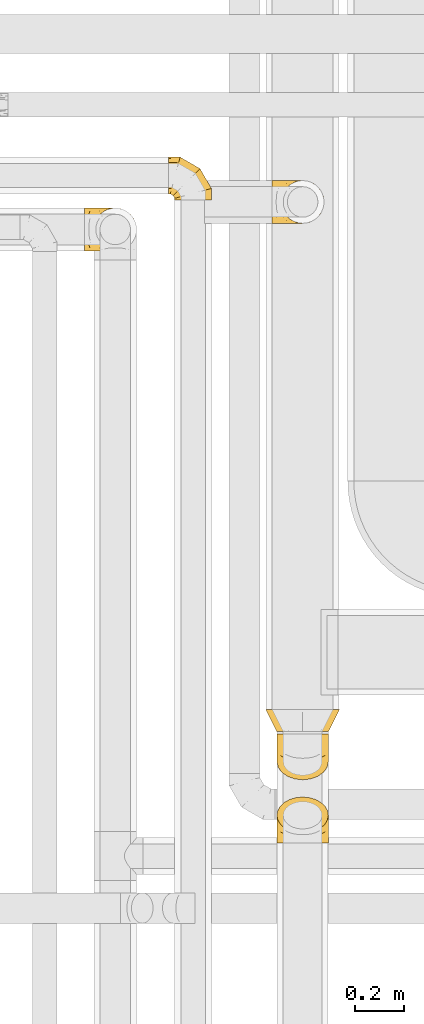
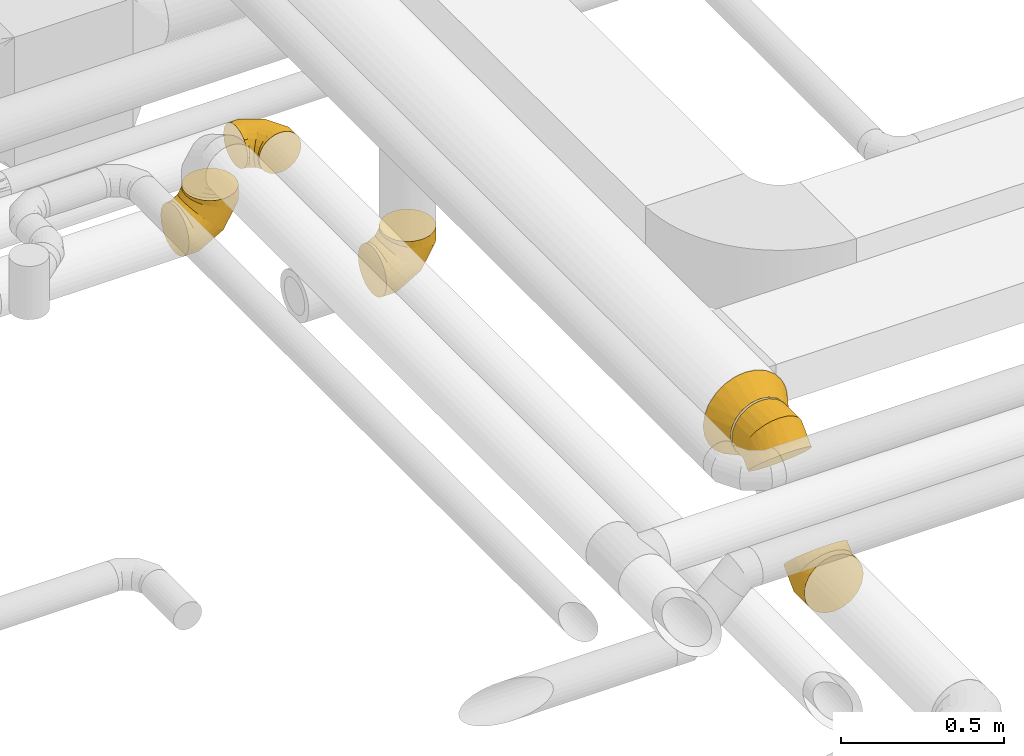
# One storey, part 24 of 92: 6 coverings.
"""IFC2X3 building model written with IfcOpenShell, lengths in millimetres."""

from ifc_helpers import new_model, entity, si_unit, converted_unit, derived_unit, direction, frame, origin, place, context, subcontext, project, spatial, faceted_brep, element, save


model = new_model("IFC2X3")

# Units and contexts
model_context = context("Model", 3, precision=0.01, world=origin(), true_north=direction((6.12303176911189e-17, 1.0)))
body_context = subcontext(model_context, "Body", "Model", "MODEL_VIEW")
ifc_project = project(units=[si_unit("LENGTHUNIT", "METRE", prefix="MILLI"), si_unit("AREAUNIT", "SQUARE_METRE"), si_unit("VOLUMEUNIT", "CUBIC_METRE"), converted_unit("PLANEANGLEUNIT", "DEGREE", entity("IfcRatioMeasure", 0.0174532925199433), si_unit("PLANEANGLEUNIT", "RADIAN"), dimensions=[0, 0, 0, 0, 0, 0, 0]), si_unit("MASSUNIT", "GRAM", prefix="KILO"), derived_unit("MASSDENSITYUNIT", [(si_unit("MASSUNIT", "GRAM", prefix="KILO"), 1), (si_unit("LENGTHUNIT", "METRE"), -3)]), derived_unit("MOMENTOFINERTIAUNIT", [(si_unit("LENGTHUNIT", "METRE"), 4)]), si_unit("TIMEUNIT", "SECOND"), si_unit("FREQUENCYUNIT", "HERTZ"), si_unit("THERMODYNAMICTEMPERATUREUNIT", "DEGREE_CELSIUS"), derived_unit("THERMALTRANSMITTANCEUNIT", [(si_unit("MASSUNIT", "GRAM", prefix="KILO"), 1), (si_unit("THERMODYNAMICTEMPERATUREUNIT", "KELVIN"), -1), (si_unit("TIMEUNIT", "SECOND"), -3)]), derived_unit("VOLUMETRICFLOWRATEUNIT", [(si_unit("LENGTHUNIT", "METRE"), 3), (si_unit("TIMEUNIT", "SECOND"), -1)]), derived_unit("MASSFLOWRATEUNIT", [(si_unit("MASSUNIT", "GRAM", prefix="KILO"), 1), (si_unit("TIMEUNIT", "SECOND"), -1)]), derived_unit("ROTATIONALFREQUENCYUNIT", [(si_unit("TIMEUNIT", "SECOND"), -1)]), si_unit("ELECTRICCURRENTUNIT", "AMPERE"), si_unit("ELECTRICVOLTAGEUNIT", "VOLT"), si_unit("POWERUNIT", "WATT"), si_unit("FORCEUNIT", "NEWTON", prefix="KILO"), si_unit("ILLUMINANCEUNIT", "LUX"), si_unit("LUMINOUSFLUXUNIT", "LUMEN"), si_unit("LUMINOUSINTENSITYUNIT", "CANDELA"), derived_unit("USERDEFINED", [(si_unit("MASSUNIT", "GRAM", prefix="KILO"), -1), (si_unit("LENGTHUNIT", "METRE"), -2), (si_unit("TIMEUNIT", "SECOND"), 3), (si_unit("LUMINOUSFLUXUNIT", "LUMEN"), 1)]), derived_unit("LINEARVELOCITYUNIT", [(si_unit("LENGTHUNIT", "METRE"), 1), (si_unit("TIMEUNIT", "SECOND"), -1)]), si_unit("PRESSUREUNIT", "PASCAL"), derived_unit("USERDEFINED", [(si_unit("LENGTHUNIT", "METRE"), -2), (si_unit("MASSUNIT", "GRAM", prefix="KILO"), 1), (si_unit("TIMEUNIT", "SECOND"), -2)]), derived_unit("LINEARFORCEUNIT", [(si_unit("MASSUNIT", "GRAM", prefix="KILO"), 1), (si_unit("LENGTHUNIT", "METRE"), 1), (si_unit("TIMEUNIT", "SECOND"), -2), (si_unit("LENGTHUNIT", "METRE"), -1)]), derived_unit("PLANARFORCEUNIT", [(si_unit("MASSUNIT", "GRAM", prefix="KILO"), 1), (si_unit("LENGTHUNIT", "METRE"), 1), (si_unit("TIMEUNIT", "SECOND"), -2), (si_unit("LENGTHUNIT", "METRE"), -2)])], contexts=[model_context])

# Site, building, storey
site_placement = place(None, origin())
site = spatial("IfcSite", under=ifc_project, at=site_placement, CompositionType="ELEMENT")
building_placement = place(site_placement, origin())
building = spatial("IfcBuilding", under=site, at=building_placement, CompositionType="ELEMENT")
storey_placement = place(building_placement, frame((0.0, 0.0, 4200.0)))
storey = spatial("IfcBuildingStorey", under=building, at=storey_placement, CompositionType="ELEMENT", Elevation=4200.0)

# Coverings
covering_1_placement = place(storey_placement, frame((60960.0, 11327.66, 2510.9)))
element("IfcCovering", 1, at=covering_1_placement, inside=storey, PredefinedType="INSULATION", context=body_context, shape_type="Brep", body=[
    faceted_brep([(97.96, 5.88, 214.1), (125.0, 1.6, 214.1), (152.04, 5.88, 214.1), (176.43, 18.31, 214.1), (195.79, 37.66, 214.1), (208.22, 62.06, 214.1), (212.5, 89.1, 214.1), (208.22, 116.13, 214.1), (195.79, 140.53, 214.1), (176.43, 159.88, 214.1), (152.04, 172.31, 214.1), (125.0, 176.6, 214.1), (97.96, 172.31, 214.1), (73.57, 159.88, 214.1), (54.21, 140.53, 214.1), (48.0, 128.33, 214.1), (41.78, 116.13, 214.1), (39.64, 102.61, 214.1), (37.5, 89.1, 214.1), (39.64, 75.58, 214.1), (41.78, 62.06, 214.1), (48.0, 49.86, 214.1), (54.21, 37.66, 214.1), (73.57, 18.31, 214.1), (0.0, 132.85, 13.32), (0.0, 111.74, 4.58), (0.0, 89.1, 1.6), (0.0, 66.45, 4.58), (0.0, 45.35, 13.32), (0.0, 27.22, 27.22), (0.0, 13.32, 45.35), (0.0, 4.58, 66.45), (0.0, 1.6, 89.1), (0.0, 4.58, 111.74), (0.0, 13.32, 132.85), (0.0, 27.22, 150.97), (0.0, 45.35, 164.87), (0.0, 66.45, 173.61), (0.0, 89.1, 176.6), (0.0, 111.74, 173.61), (0.0, 132.85, 164.87), (0.0, 150.97, 150.97), (0.0, 164.87, 132.85), (0.0, 173.61, 111.74), (0.0, 176.6, 89.1), (0.0, 173.61, 66.45), (0.0, 164.87, 45.35), (0.0, 150.97, 27.22), (56.94, 89.1, 1.6), (56.14, 66.45, 4.58), (53.8, 45.35, 13.32), (50.07, 27.22, 27.22), (45.22, 13.32, 45.35), (39.56, 4.58, 66.45), (33.49, 1.6, 89.1), (27.43, 4.58, 111.74), (21.77, 13.32, 132.85), (16.92, 27.22, 150.97), (13.19, 45.35, 164.87), (10.85, 66.45, 173.61), (10.05, 89.1, 176.6), (10.85, 111.74, 173.61), (13.19, 132.85, 164.87), (16.92, 150.97, 150.97), (27.43, 173.61, 111.74), (33.49, 176.6, 89.1), (21.77, 164.87, 132.85), (39.56, 173.61, 66.45), (45.22, 164.87, 45.35), (50.07, 150.97, 27.22), (53.8, 132.85, 13.32), (56.14, 111.74, 4.58), (155.56, 89.1, 58.53), (153.38, 66.45, 60.72), (146.98, 45.35, 67.12), (136.8, 27.22, 77.3), (123.53, 13.32, 90.56), (108.08, 4.58, 106.01), (91.51, 1.6, 122.59), (74.93, 4.58, 139.17), (59.48, 13.32, 154.62), (46.21, 27.22, 167.88), (36.03, 45.35, 178.06), (29.63, 66.45, 184.46), (27.45, 89.1, 186.64), (29.63, 111.74, 184.46), (36.03, 132.85, 178.06), (46.21, 150.97, 167.88), (74.93, 173.61, 139.17), (91.51, 176.6, 122.59), (59.48, 164.87, 154.62), (108.08, 173.61, 106.01), (123.53, 164.87, 90.56), (136.8, 150.97, 77.3), (146.98, 132.85, 67.12), (153.38, 111.74, 60.72), (212.5, 89.1, 157.16), (209.52, 66.45, 157.95), (200.78, 45.35, 160.3), (186.87, 27.22, 164.02), (168.75, 13.32, 168.88), (147.65, 4.58, 174.53), (125.0, 1.6, 180.6), (102.35, 4.58, 186.67), (81.25, 13.32, 192.32), (63.13, 27.22, 197.18), (49.22, 45.35, 200.91), (40.48, 66.45, 203.25), (38.99, 77.77, 203.65), (37.5, 89.1, 204.05), (40.48, 111.74, 203.25), (49.22, 132.85, 200.91), (38.99, 100.42, 203.65), (63.13, 150.97, 197.18), (102.35, 173.61, 186.67), (125.0, 176.6, 180.6), (81.25, 164.87, 192.32), (147.65, 173.61, 174.53), (168.75, 164.87, 168.88), (186.87, 150.97, 164.02), (200.78, 132.85, 160.3), (209.52, 111.74, 157.95)], [[[0, 1, 2, 3, 4, 5, 6, 7, 8, 9, 10, 11, 12, 13, 14, 15, 16, 17, 18, 19, 20, 21, 22, 23]], [[24, 25, 26, 27, 28, 29, 30, 31, 32, 33, 34, 35, 36, 37, 38, 39, 40, 41, 42, 43, 44, 45, 46, 47]], [[26, 48, 49, 27]], [[27, 49, 50, 28]], [[28, 50, 51, 29]], [[30, 52, 53, 31]], [[31, 53, 54, 32]], [[29, 51, 52, 30]], [[55, 56, 34, 33]], [[54, 55, 33, 32]], [[57, 35, 34, 56]], [[58, 59, 37, 36]], [[58, 36, 35, 57]], [[60, 38, 37, 59]], [[61, 62, 40, 39]], [[60, 61, 39, 38]], [[41, 40, 62, 63]], [[64, 65, 44, 43]], [[66, 64, 43, 42]], [[63, 66, 42, 41]], [[46, 45, 67, 68]], [[47, 46, 68, 69]], [[44, 65, 67, 45]], [[25, 24, 70, 71]], [[26, 25, 71, 48]], [[69, 70, 24, 47]], [[49, 48, 72, 73]], [[50, 49, 73, 74]], [[74, 75, 51, 50]], [[52, 51, 75, 76]], [[53, 52, 76, 77]], [[54, 53, 77, 78]], [[79, 80, 56, 55]], [[78, 79, 55, 54]], [[57, 56, 80, 81]], [[82, 83, 59, 58]], [[81, 82, 58, 57]], [[60, 59, 83, 84]], [[85, 86, 62, 61]], [[84, 85, 61, 60]], [[63, 62, 86, 87]], [[88, 89, 65, 64]], [[90, 88, 64, 66]], [[87, 90, 66, 63]], [[67, 65, 89, 91]], [[68, 67, 91, 92]], [[69, 68, 92, 93]], [[71, 70, 94, 95]], [[48, 71, 95, 72]], [[93, 94, 70, 69]], [[73, 72, 96, 97]], [[74, 73, 97, 98]], [[98, 99, 75, 74]], [[76, 75, 99, 100]], [[77, 76, 100, 101]], [[78, 77, 101, 102]], [[103, 104, 80, 79]], [[102, 103, 79, 78]], [[81, 80, 104, 105]], [[106, 107, 83, 82]], [[105, 106, 82, 81]], [[84, 83, 107, 108, 109]], [[110, 111, 86, 85]], [[85, 84, 109, 112, 110]], [[87, 86, 111, 113]], [[114, 115, 89, 88]], [[116, 114, 88, 90]], [[113, 116, 90, 87]], [[91, 89, 115, 117]], [[92, 91, 117, 118]], [[93, 92, 118, 119]], [[95, 94, 120, 121]], [[72, 95, 121, 96]], [[119, 120, 94, 93]], [[97, 6, 5]], [[98, 5, 4]], [[6, 97, 96]], [[97, 5, 98]], [[4, 99, 98]], [[100, 3, 2]], [[101, 2, 1]], [[99, 3, 100]], [[100, 2, 101]], [[1, 102, 101]], [[3, 99, 4]], [[103, 1, 0]], [[104, 0, 23]], [[103, 102, 1]], [[104, 103, 0]], [[23, 105, 104]], [[21, 20, 107]], [[18, 109, 108]], [[107, 20, 19]], [[106, 105, 22]], [[106, 22, 21]], [[107, 19, 108]], [[21, 107, 106]], [[18, 108, 19]], [[22, 105, 23]], [[110, 17, 16]], [[111, 15, 14]], [[18, 112, 109]], [[18, 17, 112]], [[110, 16, 15]], [[110, 15, 111]], [[14, 113, 111]], [[116, 13, 12]], [[114, 12, 11]], [[116, 113, 13]], [[115, 114, 11]], [[116, 12, 114]], [[17, 110, 112]], [[13, 113, 14]], [[117, 11, 10]], [[118, 10, 9]], [[11, 117, 115]], [[117, 10, 118]], [[9, 119, 118]], [[120, 8, 7]], [[121, 7, 6]], [[119, 8, 120]], [[121, 120, 7]], [[96, 121, 6]], [[8, 119, 9]]]),
])
covering_2_placement = place(storey_placement, frame((60933.4, 9251.14, 3130.9)))
element("IfcCovering", 2, at=covering_2_placement, inside=storey, PredefinedType="INSULATION", context=body_context, shape_type="Brep", body=[
    faceted_brep([(190.42, 90.0, 296.48), (226.6, 90.0, 281.5), (257.66, 90.0, 257.66), (281.5, 90.0, 226.6), (296.48, 90.0, 190.42), (301.6, 90.0, 151.6), (296.48, 90.0, 112.77), (281.5, 90.0, 76.6), (257.66, 90.0, 45.53), (226.6, 90.0, 21.69), (190.42, 90.0, 6.71), (151.6, 90.0, 1.6), (112.77, 90.0, 6.71), (76.6, 90.0, 21.69), (45.53, 90.0, 45.53), (21.69, 90.0, 76.6), (6.71, 90.0, 112.77), (1.6, 90.0, 151.6), (6.71, 90.0, 190.42), (21.69, 90.0, 226.6), (45.53, 90.0, 257.66), (76.6, 90.0, 281.5), (112.77, 90.0, 296.48), (151.6, 90.0, 301.6), (184.04, 0.0, 251.46), (151.6, 0.0, 256.6), (119.15, 0.0, 251.46), (89.88, 0.0, 236.54), (66.65, 0.0, 213.31), (51.73, 0.0, 184.04), (46.6, 0.0, 151.6), (51.73, 0.0, 119.15), (66.65, 0.0, 89.88), (89.88, 0.0, 66.65), (119.15, 0.0, 51.73), (151.6, 0.0, 46.6), (184.04, 0.0, 51.73), (213.31, 0.0, 66.65), (236.54, 0.0, 89.88), (251.46, 0.0, 119.15), (256.6, 0.0, 151.6), (251.46, 0.0, 184.04), (236.54, 0.0, 213.31), (213.31, 0.0, 236.54)], [[[0, 1, 2, 3, 4, 5, 6, 7, 8, 9, 10, 11, 12, 13, 14, 15, 16, 17, 18, 19, 20, 21, 22, 23]], [[24, 25, 26, 27, 28, 29, 30, 31, 32, 33, 34, 35, 36, 37, 38, 39, 40, 41, 42, 43]], [[6, 40, 39]], [[7, 39, 38]], [[6, 5, 40]], [[7, 6, 39]], [[38, 8, 7]], [[36, 35, 10]], [[37, 36, 9]], [[8, 37, 9]], [[10, 9, 36]], [[11, 10, 35]], [[37, 8, 38]], [[12, 35, 34]], [[13, 34, 33]], [[12, 11, 35]], [[13, 12, 34]], [[33, 14, 13]], [[31, 30, 16]], [[32, 31, 15]], [[14, 32, 15]], [[16, 15, 31]], [[17, 16, 30]], [[32, 14, 33]], [[18, 30, 29]], [[19, 29, 28]], [[18, 17, 30]], [[19, 18, 29]], [[28, 20, 19]], [[26, 25, 22]], [[27, 26, 21]], [[20, 27, 21]], [[22, 21, 26]], [[23, 22, 25]], [[27, 20, 28]], [[0, 25, 24]], [[1, 24, 43]], [[0, 23, 25]], [[1, 0, 24]], [[43, 2, 1]], [[41, 40, 4]], [[42, 41, 3]], [[2, 42, 3]], [[4, 3, 41]], [[5, 4, 40]], [[42, 2, 43]]]),
])
covering_3_placement = place(storey_placement, frame((60978.4, 9052.72, 3159.8)))
element("IfcCovering", 3, at=covering_3_placement, inside=storey, PredefinedType="INSULATION", context=body_context, shape_type="Brep", body=[
    faceted_brep([(6.73, 52.9, 98.78), (1.6, 75.84, 75.84), (6.73, 98.78, 52.9), (21.65, 119.48, 32.2), (44.88, 135.91, 15.78), (74.15, 146.45, 5.23), (106.6, 150.09, 1.6), (139.04, 146.45, 5.23), (168.31, 135.91, 15.78), (191.54, 119.48, 32.2), (206.46, 98.78, 52.9), (211.6, 75.84, 75.84), (206.46, 52.9, 98.78), (191.54, 32.2, 119.48), (168.31, 15.78, 135.91), (139.04, 5.23, 146.45), (106.6, 1.6, 150.09), (74.15, 5.23, 146.45), (44.88, 15.78, 135.91), (21.65, 32.2, 119.48), (54.1, 188.98, 213.64), (79.42, 188.98, 224.13), (106.6, 188.98, 227.7), (133.77, 188.98, 224.13), (159.1, 188.98, 213.64), (180.84, 188.98, 196.95), (197.53, 188.98, 175.2), (208.02, 188.98, 149.88), (211.6, 188.98, 122.7), (208.02, 188.98, 95.53), (197.53, 188.98, 70.2), (180.84, 188.98, 48.46), (159.1, 188.98, 31.77), (133.77, 188.98, 21.28), (106.6, 188.98, 17.7), (79.42, 188.98, 21.28), (54.1, 188.98, 31.77), (32.35, 188.98, 48.46), (15.66, 188.98, 70.2), (5.17, 188.98, 95.53), (1.6, 188.98, 122.7), (5.17, 188.98, 149.88), (15.66, 188.98, 175.2), (32.35, 188.98, 196.95), (106.6, 79.21, 227.7), (133.77, 80.69, 224.13), (159.1, 85.04, 213.64), (180.84, 91.95, 196.95), (197.53, 100.96, 175.2), (208.02, 111.45, 149.88), (211.6, 122.7, 122.7), (208.02, 133.96, 95.53), (197.53, 144.45, 70.2), (180.84, 153.46, 48.46), (133.77, 164.71, 21.28), (106.6, 166.2, 17.7), (159.1, 160.37, 31.77), (54.1, 160.37, 31.77), (32.35, 153.46, 48.46), (79.42, 164.71, 21.28), (5.17, 133.96, 95.53), (1.6, 122.7, 122.7), (15.66, 144.45, 70.2), (5.17, 111.45, 149.88), (15.66, 100.96, 175.2), (32.35, 91.95, 196.95), (54.1, 85.04, 213.64), (79.42, 80.69, 224.13)], [[[0, 1, 2, 3, 4, 5, 6, 7, 8, 9, 10, 11, 12, 13, 14, 15, 16, 17, 18, 19]], [[20, 21, 22, 23, 24, 25, 26, 27, 28, 29, 30, 31, 32, 33, 34, 35, 36, 37, 38, 39, 40, 41, 42, 43]], [[22, 44, 45, 23]], [[23, 45, 46, 24]], [[47, 25, 24, 46]], [[25, 47, 48, 26]], [[26, 48, 49, 27]], [[50, 28, 27, 49]], [[51, 52, 30, 29]], [[50, 51, 29, 28]], [[30, 52, 53, 31]], [[54, 55, 34, 33]], [[56, 54, 33, 32]], [[31, 53, 56, 32]], [[36, 57, 58, 37]], [[59, 57, 36, 35]], [[34, 55, 59, 35]], [[60, 61, 40, 39]], [[62, 60, 39, 38]], [[58, 62, 38, 37]], [[41, 40, 61, 63]], [[42, 41, 63, 64]], [[64, 65, 43, 42]], [[21, 20, 66, 67]], [[22, 21, 67, 44]], [[65, 66, 20, 43]], [[15, 14, 46]], [[16, 15, 45]], [[16, 45, 44]], [[45, 15, 46]], [[14, 47, 46]], [[48, 13, 12]], [[49, 12, 11]], [[47, 13, 48]], [[48, 12, 49]], [[11, 50, 49]], [[13, 47, 14]], [[51, 11, 10]], [[52, 10, 9]], [[51, 50, 11]], [[52, 51, 10]], [[9, 53, 52]], [[56, 8, 7]], [[54, 7, 6]], [[56, 53, 8]], [[55, 54, 6]], [[56, 7, 54]], [[8, 53, 9]], [[5, 4, 57]], [[6, 5, 59]], [[59, 55, 6]], [[57, 59, 5]], [[4, 58, 57]], [[62, 3, 2]], [[60, 2, 1]], [[62, 58, 3]], [[61, 60, 1]], [[62, 2, 60]], [[3, 58, 4]], [[63, 1, 0]], [[64, 0, 19]], [[1, 63, 61]], [[63, 0, 64]], [[19, 65, 64]], [[66, 18, 17]], [[67, 17, 16]], [[65, 18, 66]], [[67, 66, 17]], [[44, 67, 16]], [[18, 65, 19]]]),
])
covering_4_placement = place(storey_placement, frame((60978.4, 8796.65, 2863.4)))
element("IfcCovering", 4, at=covering_4_placement, inside=storey, PredefinedType="INSULATION", context=body_context, shape_type="Brep", body=[
    faceted_brep([(106.6, 0.0, 211.6), (74.15, 0.0, 206.46), (44.88, 0.0, 191.54), (21.65, 0.0, 168.31), (6.73, 0.0, 139.04), (1.6, 0.0, 106.6), (6.73, 0.0, 74.15), (21.65, 0.0, 44.88), (44.88, 0.0, 21.65), (74.15, 0.0, 6.73), (106.6, 0.0, 1.6), (139.04, 0.0, 6.73), (168.31, 0.0, 21.65), (191.54, 0.0, 44.88), (206.46, 0.0, 74.15), (211.6, 0.0, 106.6), (206.46, 0.0, 139.04), (191.54, 0.0, 168.31), (168.31, 0.0, 191.54), (139.04, 0.0, 206.46), (159.1, 177.44, 89.16), (133.77, 184.85, 81.74), (106.6, 187.38, 79.21), (79.42, 184.85, 81.74), (54.1, 177.44, 89.16), (32.35, 165.64, 100.96), (15.66, 150.26, 116.34), (5.17, 132.35, 134.24), (1.6, 113.14, 153.46), (5.17, 93.92, 172.67), (15.66, 76.01, 190.58), (32.35, 60.64, 205.96), (54.1, 48.84, 217.76), (79.42, 41.42, 225.17), (106.6, 38.89, 227.7), (133.77, 41.42, 225.17), (159.1, 48.84, 217.76), (180.84, 60.64, 205.96), (197.53, 76.01, 190.58), (208.02, 93.92, 172.67), (211.6, 113.14, 153.46), (208.02, 132.35, 134.24), (197.53, 150.26, 116.34), (180.84, 165.64, 100.96), (106.6, 109.77, 1.6), (79.42, 108.28, 5.17), (54.1, 103.94, 15.66), (32.35, 97.03, 32.35), (15.66, 88.02, 54.1), (5.17, 77.53, 79.42), (1.6, 66.27, 106.6), (5.17, 55.02, 133.77), (15.66, 44.53, 159.1), (32.35, 35.52, 180.84), (79.42, 24.26, 208.02), (106.6, 22.78, 211.6), (54.1, 28.61, 197.53), (159.1, 28.61, 197.53), (180.84, 35.52, 180.84), (133.77, 24.26, 208.02), (208.02, 55.02, 133.77), (211.6, 66.27, 106.6), (197.53, 44.53, 159.1), (208.02, 77.53, 79.42), (197.53, 88.02, 54.1), (180.84, 97.03, 32.35), (159.1, 103.94, 15.66), (133.77, 108.28, 5.17)], [[[0, 1, 2, 3, 4, 5, 6, 7, 8, 9, 10, 11, 12, 13, 14, 15, 16, 17, 18, 19]], [[20, 21, 22, 23, 24, 25, 26, 27, 28, 29, 30, 31, 32, 33, 34, 35, 36, 37, 38, 39, 40, 41, 42, 43]], [[22, 44, 45, 23]], [[23, 45, 46, 24]], [[47, 25, 24, 46]], [[25, 47, 48, 26]], [[26, 48, 49, 27]], [[50, 28, 27, 49]], [[51, 52, 30, 29]], [[50, 51, 29, 28]], [[30, 52, 53, 31]], [[54, 55, 34, 33]], [[56, 54, 33, 32]], [[31, 53, 56, 32]], [[36, 57, 58, 37]], [[59, 57, 36, 35]], [[34, 55, 59, 35]], [[60, 61, 40, 39]], [[62, 60, 39, 38]], [[58, 62, 38, 37]], [[41, 40, 61, 63]], [[42, 41, 63, 64]], [[64, 65, 43, 42]], [[21, 20, 66, 67]], [[22, 21, 67, 44]], [[65, 66, 20, 43]], [[9, 8, 46]], [[10, 9, 45]], [[10, 45, 44]], [[45, 9, 46]], [[8, 47, 46]], [[48, 7, 6]], [[49, 6, 5]], [[47, 7, 48]], [[48, 6, 49]], [[5, 50, 49]], [[7, 47, 8]], [[51, 5, 4]], [[52, 4, 3]], [[51, 50, 5]], [[52, 51, 4]], [[3, 53, 52]], [[56, 2, 1]], [[54, 1, 0]], [[56, 53, 2]], [[55, 54, 0]], [[56, 1, 54]], [[2, 53, 3]], [[19, 18, 57]], [[0, 19, 59]], [[59, 55, 0]], [[57, 59, 19]], [[18, 58, 57]], [[62, 17, 16]], [[60, 16, 15]], [[62, 58, 17]], [[61, 60, 15]], [[62, 16, 60]], [[17, 58, 18]], [[63, 15, 14]], [[64, 14, 13]], [[15, 63, 61]], [[63, 14, 64]], [[13, 65, 64]], [[66, 12, 11]], [[67, 11, 10]], [[65, 12, 66]], [[67, 66, 11]], [[44, 67, 10]], [[12, 65, 13]]]),
])
covering_5_placement = place(storey_placement, frame((60537.13, 11424.89, 3073.4)))
element("IfcCovering", 5, at=covering_5_placement, inside=storey, PredefinedType="INSULATION", context=body_context, shape_type="Brep", body=[
    faceted_brep([(0.0, 169.29, 105.3), (0.0, 172.15, 90.95), (0.0, 175.0, 76.6), (0.0, 172.15, 62.24), (0.0, 169.29, 47.89), (0.0, 161.16, 35.73), (0.0, 153.03, 23.56), (0.0, 140.87, 15.43), (0.0, 128.7, 7.3), (0.0, 114.35, 4.45), (0.0, 100.0, 1.6), (0.0, 85.65, 4.45), (0.0, 71.3, 7.3), (0.0, 59.13, 15.43), (0.0, 46.97, 23.56), (0.0, 38.84, 35.73), (0.0, 30.71, 47.89), (0.0, 27.85, 62.24), (0.0, 26.43, 69.42), (0.0, 25.0, 76.6), (0.0, 26.43, 83.77), (0.0, 27.85, 90.95), (0.0, 30.71, 105.3), (0.0, 38.84, 117.46), (0.0, 46.97, 129.63), (0.0, 59.13, 137.76), (0.0, 71.3, 145.89), (0.0, 85.65, 148.74), (0.0, 100.0, 151.6), (0.0, 114.35, 148.74), (0.0, 128.7, 145.89), (0.0, 140.87, 137.76), (0.0, 153.03, 129.63), (0.0, 161.16, 117.46), (172.44, 0.0, 57.18), (175.0, 0.0, 76.6), (172.44, 0.0, 96.01), (164.95, 0.0, 114.1), (153.03, 0.0, 129.63), (137.5, 0.0, 141.55), (119.41, 0.0, 149.04), (100.0, 0.0, 151.6), (80.59, 0.0, 149.04), (62.5, 0.0, 141.55), (46.97, 0.0, 129.63), (35.05, 0.0, 114.1), (27.56, 0.0, 96.01), (25.0, 0.0, 76.6), (27.56, 0.0, 57.18), (35.05, 0.0, 39.1), (46.97, 0.0, 23.56), (62.5, 0.0, 11.64), (80.59, 0.0, 4.15), (100.0, 0.0, 1.6), (119.41, 0.0, 4.15), (137.5, 0.0, 11.64), (153.03, 0.0, 23.56), (164.95, 0.0, 39.1), (175.0, 46.89, 76.6), (172.44, 46.21, 96.01), (164.95, 44.2, 114.1), (153.03, 41.01, 129.63), (137.5, 36.84, 141.55), (119.41, 32.0, 149.04), (100.0, 26.79, 151.6), (80.59, 21.59, 149.04), (62.5, 16.75, 141.55), (46.97, 12.58, 129.63), (35.05, 9.39, 114.1), (27.56, 7.38, 96.01), (25.0, 6.7, 76.6), (27.56, 7.38, 57.18), (35.05, 9.39, 39.1), (46.97, 12.58, 23.56), (80.59, 21.59, 4.15), (100.0, 26.79, 1.6), (62.5, 16.75, 11.64), (119.41, 32.0, 4.15), (137.5, 36.84, 11.64), (153.03, 41.01, 23.56), (164.95, 44.2, 39.1), (172.44, 46.21, 57.18), (128.11, 128.11, 76.6), (126.24, 126.24, 96.01), (120.75, 120.75, 114.1), (112.03, 112.03, 129.63), (100.66, 100.66, 141.55), (87.42, 87.42, 149.04), (73.21, 73.21, 151.6), (58.99, 58.99, 149.04), (45.75, 45.75, 141.55), (34.38, 34.38, 129.63), (25.66, 25.66, 114.1), (20.17, 20.17, 96.01), (18.3, 18.3, 76.6), (20.17, 20.17, 57.18), (25.66, 25.66, 39.1), (34.38, 34.38, 23.56), (58.99, 58.99, 4.15), (73.21, 73.21, 1.6), (45.75, 45.75, 11.64), (87.42, 87.42, 4.15), (100.66, 100.66, 11.64), (112.03, 112.03, 23.56), (120.75, 120.75, 39.1), (126.24, 126.24, 57.18), (46.89, 175.0, 76.6), (46.21, 172.44, 96.01), (44.2, 164.95, 114.1), (41.01, 153.03, 129.63), (36.84, 137.5, 141.55), (32.0, 119.41, 149.04), (26.79, 100.0, 151.6), (21.59, 80.59, 149.04), (16.75, 62.5, 141.55), (12.58, 46.97, 129.63), (9.39, 35.05, 114.1), (8.39, 31.3, 105.05), (7.38, 27.56, 96.01), (7.04, 26.28, 86.3), (6.7, 25.0, 76.6), (7.38, 27.56, 57.18), (8.39, 31.3, 48.14), (9.39, 35.05, 39.1), (7.04, 26.28, 66.89), (12.58, 46.97, 23.56), (21.59, 80.59, 4.15), (26.79, 100.0, 1.6), (16.75, 62.5, 11.64), (32.0, 119.41, 4.15), (36.84, 137.5, 11.64), (41.01, 153.03, 23.56), (44.2, 164.95, 39.1), (46.21, 172.44, 57.18)], [[[0, 1, 2, 3, 4, 5, 6, 7, 8, 9, 10, 11, 12, 13, 14, 15, 16, 17, 18, 19, 20, 21, 22, 23, 24, 25, 26, 27, 28, 29, 30, 31, 32, 33]], [[34, 35, 36, 37, 38, 39, 40, 41, 42, 43, 44, 45, 46, 47, 48, 49, 50, 51, 52, 53, 54, 55, 56, 57]], [[35, 58, 59, 36]], [[36, 59, 60, 37]], [[37, 60, 61, 38]], [[39, 62, 63, 40]], [[40, 63, 64, 41]], [[38, 61, 62, 39]], [[65, 66, 43, 42]], [[64, 65, 42, 41]], [[67, 44, 43, 66]], [[68, 69, 46, 45]], [[68, 45, 44, 67]], [[70, 47, 46, 69]], [[71, 72, 49, 48]], [[70, 71, 48, 47]], [[50, 49, 72, 73]], [[74, 75, 53, 52]], [[76, 74, 52, 51]], [[73, 76, 51, 50]], [[55, 54, 77, 78]], [[56, 55, 78, 79]], [[53, 75, 77, 54]], [[34, 57, 80, 81]], [[35, 34, 81, 58]], [[79, 80, 57, 56]], [[58, 82, 83, 59]], [[60, 59, 83, 84]], [[84, 85, 61, 60]], [[62, 61, 85, 86]], [[63, 62, 86, 87]], [[64, 63, 87, 88]], [[89, 90, 66, 65]], [[88, 89, 65, 64]], [[67, 66, 90, 91]], [[92, 93, 69, 68]], [[91, 92, 68, 67]], [[70, 69, 93, 94]], [[95, 96, 72, 71]], [[94, 95, 71, 70]], [[73, 72, 96, 97]], [[98, 99, 75, 74]], [[100, 98, 74, 76]], [[97, 100, 76, 73]], [[77, 75, 99, 101]], [[78, 77, 101, 102]], [[79, 78, 102, 103]], [[81, 80, 104, 105]], [[58, 81, 105, 82]], [[103, 104, 80, 79]], [[82, 106, 107, 83]], [[84, 83, 107, 108]], [[108, 109, 85, 84]], [[86, 85, 109, 110]], [[87, 86, 110, 111]], [[88, 87, 111, 112]], [[113, 114, 90, 89]], [[112, 113, 89, 88]], [[91, 90, 114, 115]], [[93, 92, 116, 117, 118]], [[115, 116, 92, 91]], [[94, 93, 118, 119, 120]], [[95, 121, 122, 123, 96]], [[94, 120, 124, 121, 95]], [[97, 96, 123, 125]], [[126, 127, 99, 98]], [[128, 126, 98, 100]], [[125, 128, 100, 97]], [[101, 99, 127, 129]], [[102, 101, 129, 130]], [[103, 102, 130, 131]], [[105, 104, 132, 133]], [[82, 105, 133, 106]], [[131, 132, 104, 103]], [[106, 1, 107]], [[111, 30, 29]], [[1, 106, 2]], [[32, 109, 33]], [[108, 0, 33]], [[107, 0, 108]], [[31, 30, 110]], [[108, 33, 109]], [[31, 109, 32]], [[28, 112, 29]], [[1, 0, 107]], [[112, 111, 29]], [[110, 30, 111]], [[109, 31, 110]], [[113, 28, 27, 26]], [[24, 115, 25]], [[119, 21, 20]], [[114, 26, 25]], [[114, 113, 26]], [[120, 20, 19]], [[114, 25, 115]], [[28, 113, 112]], [[120, 119, 20]], [[21, 119, 118]], [[22, 118, 117, 116]], [[24, 23, 115]], [[115, 23, 116]], [[118, 22, 21]], [[116, 23, 22]], [[121, 17, 16]], [[15, 14, 125]], [[16, 123, 122, 121]], [[18, 17, 124]], [[18, 120, 19]], [[125, 123, 15]], [[13, 125, 14]], [[126, 12, 11, 10]], [[125, 13, 128]], [[120, 18, 124]], [[126, 128, 12]], [[126, 10, 127]], [[17, 121, 124]], [[123, 16, 15]], [[13, 12, 128]], [[127, 9, 129]], [[6, 131, 7]], [[130, 8, 7]], [[129, 8, 130]], [[5, 131, 6]], [[9, 8, 129]], [[130, 7, 131]], [[9, 127, 10]], [[133, 4, 3]], [[131, 5, 132]], [[2, 106, 3]], [[4, 133, 132]], [[106, 133, 3]], [[5, 4, 132]]]),
])
covering_6_placement = place(storey_placement, frame((60193.95, 11215.09, 3000.9)))
element("IfcCovering", 6, at=covering_6_placement, inside=storey, PredefinedType="INSULATION", context=body_context, shape_type="Brep", body=[
    faceted_brep([(0.0, 172.31, 116.13), (0.0, 176.6, 89.1), (0.0, 172.31, 62.06), (0.0, 159.88, 37.66), (0.0, 140.53, 18.31), (0.0, 116.13, 5.88), (0.0, 89.1, 1.6), (0.0, 62.06, 5.88), (0.0, 37.66, 18.31), (0.0, 18.31, 37.66), (0.0, 5.88, 62.06), (0.0, 1.6, 89.1), (0.0, 5.88, 116.13), (0.0, 18.31, 140.53), (0.0, 37.66, 159.88), (0.0, 49.86, 166.1), (0.0, 62.06, 172.31), (0.0, 75.58, 174.45), (0.0, 89.1, 176.6), (0.0, 102.61, 174.45), (0.0, 116.13, 172.31), (0.0, 128.33, 166.1), (0.0, 140.53, 159.88), (0.0, 159.88, 140.53), (200.78, 45.35, 214.1), (209.52, 66.45, 214.1), (212.5, 89.1, 214.1), (209.52, 111.74, 214.1), (200.78, 132.85, 214.1), (186.87, 150.97, 214.1), (168.75, 164.87, 214.1), (147.65, 173.61, 214.1), (125.0, 176.6, 214.1), (102.35, 173.61, 214.1), (81.25, 164.87, 214.1), (63.13, 150.97, 214.1), (49.22, 132.85, 214.1), (40.48, 111.74, 214.1), (37.5, 89.1, 214.1), (40.48, 66.45, 214.1), (49.22, 45.35, 214.1), (63.13, 27.22, 214.1), (81.25, 13.32, 214.1), (102.35, 4.58, 214.1), (125.0, 1.6, 214.1), (147.65, 4.58, 214.1), (168.75, 13.32, 214.1), (186.87, 27.22, 214.1), (212.5, 89.1, 157.16), (209.52, 111.74, 157.95), (200.78, 132.85, 160.3), (186.87, 150.97, 164.02), (168.75, 164.87, 168.88), (147.65, 173.61, 174.53), (125.0, 176.6, 180.6), (102.35, 173.61, 186.67), (81.25, 164.87, 192.32), (63.13, 150.97, 197.18), (49.22, 132.85, 200.91), (40.48, 111.74, 203.25), (37.5, 89.1, 204.05), (40.48, 66.45, 203.25), (49.22, 45.35, 200.91), (63.13, 27.22, 197.18), (102.35, 4.58, 186.67), (125.0, 1.6, 180.6), (81.25, 13.32, 192.32), (147.65, 4.58, 174.53), (168.75, 13.32, 168.88), (186.87, 27.22, 164.02), (200.78, 45.35, 160.3), (209.52, 66.45, 157.95), (155.56, 89.1, 58.53), (153.38, 111.74, 60.72), (146.98, 132.85, 67.12), (136.8, 150.97, 77.3), (123.53, 164.87, 90.56), (108.08, 173.61, 106.01), (91.51, 176.6, 122.59), (74.93, 173.61, 139.17), (59.48, 164.87, 154.62), (46.21, 150.97, 167.88), (36.03, 132.85, 178.06), (29.63, 111.74, 184.46), (27.45, 89.1, 186.64), (29.63, 66.45, 184.46), (36.03, 45.35, 178.06), (46.21, 27.22, 167.88), (74.93, 4.58, 139.17), (91.51, 1.6, 122.59), (59.48, 13.32, 154.62), (108.08, 4.58, 106.01), (123.53, 13.32, 90.56), (136.8, 27.22, 77.3), (146.98, 45.35, 67.12), (153.38, 66.45, 60.72), (56.94, 89.1, 1.6), (56.14, 111.74, 4.58), (53.8, 132.85, 13.32), (50.07, 150.97, 27.22), (45.22, 164.87, 45.35), (39.56, 173.61, 66.45), (33.49, 176.6, 89.1), (27.43, 173.61, 111.74), (21.77, 164.87, 132.85), (16.92, 150.97, 150.97), (13.19, 132.85, 164.87), (10.85, 111.74, 173.61), (10.45, 100.42, 175.1), (10.05, 89.1, 176.6), (10.85, 66.45, 173.61), (13.19, 45.35, 164.87), (10.45, 77.77, 175.1), (16.92, 27.22, 150.97), (27.43, 4.58, 111.74), (33.49, 1.6, 89.1), (21.77, 13.32, 132.85), (39.56, 4.58, 66.45), (45.22, 13.32, 45.35), (50.07, 27.22, 27.22), (53.8, 45.35, 13.32), (56.14, 66.45, 4.58)], [[[0, 1, 2, 3, 4, 5, 6, 7, 8, 9, 10, 11, 12, 13, 14, 15, 16, 17, 18, 19, 20, 21, 22, 23]], [[24, 25, 26, 27, 28, 29, 30, 31, 32, 33, 34, 35, 36, 37, 38, 39, 40, 41, 42, 43, 44, 45, 46, 47]], [[26, 48, 49, 27]], [[27, 49, 50, 28]], [[28, 50, 51, 29]], [[30, 52, 53, 31]], [[31, 53, 54, 32]], [[29, 51, 52, 30]], [[55, 56, 34, 33]], [[54, 55, 33, 32]], [[57, 35, 34, 56]], [[58, 59, 37, 36]], [[58, 36, 35, 57]], [[60, 38, 37, 59]], [[61, 62, 40, 39]], [[60, 61, 39, 38]], [[41, 40, 62, 63]], [[64, 65, 44, 43]], [[66, 64, 43, 42]], [[63, 66, 42, 41]], [[46, 45, 67, 68]], [[47, 46, 68, 69]], [[44, 65, 67, 45]], [[25, 24, 70, 71]], [[26, 25, 71, 48]], [[69, 70, 24, 47]], [[49, 48, 72, 73]], [[50, 49, 73, 74]], [[74, 75, 51, 50]], [[52, 51, 75, 76]], [[53, 52, 76, 77]], [[54, 53, 77, 78]], [[79, 80, 56, 55]], [[78, 79, 55, 54]], [[57, 56, 80, 81]], [[82, 83, 59, 58]], [[81, 82, 58, 57]], [[60, 59, 83, 84]], [[85, 86, 62, 61]], [[84, 85, 61, 60]], [[63, 62, 86, 87]], [[88, 89, 65, 64]], [[90, 88, 64, 66]], [[87, 90, 66, 63]], [[67, 65, 89, 91]], [[68, 67, 91, 92]], [[69, 68, 92, 93]], [[71, 70, 94, 95]], [[48, 71, 95, 72]], [[93, 94, 70, 69]], [[73, 72, 96, 97]], [[74, 73, 97, 98]], [[98, 99, 75, 74]], [[76, 75, 99, 100]], [[77, 76, 100, 101]], [[78, 77, 101, 102]], [[103, 104, 80, 79]], [[102, 103, 79, 78]], [[81, 80, 104, 105]], [[106, 107, 83, 82]], [[105, 106, 82, 81]], [[84, 83, 107, 108, 109]], [[110, 111, 86, 85]], [[85, 84, 109, 112, 110]], [[87, 86, 111, 113]], [[114, 115, 89, 88]], [[116, 114, 88, 90]], [[113, 116, 90, 87]], [[91, 89, 115, 117]], [[92, 91, 117, 118]], [[93, 92, 118, 119]], [[95, 94, 120, 121]], [[72, 95, 121, 96]], [[119, 120, 94, 93]], [[97, 6, 5]], [[98, 5, 4]], [[6, 97, 96]], [[97, 5, 98]], [[4, 99, 98]], [[100, 3, 2]], [[101, 2, 1]], [[99, 3, 100]], [[100, 2, 101]], [[1, 102, 101]], [[3, 99, 4]], [[103, 1, 0]], [[104, 0, 23]], [[103, 102, 1]], [[104, 103, 0]], [[23, 105, 104]], [[21, 20, 107]], [[18, 109, 108]], [[107, 20, 19]], [[106, 105, 22]], [[106, 22, 21]], [[107, 19, 108]], [[21, 107, 106]], [[18, 108, 19]], [[22, 105, 23]], [[110, 17, 16]], [[111, 15, 14]], [[18, 112, 109]], [[18, 17, 112]], [[110, 16, 15]], [[110, 15, 111]], [[14, 113, 111]], [[116, 13, 12]], [[114, 12, 11]], [[116, 113, 13]], [[115, 114, 11]], [[116, 12, 114]], [[17, 110, 112]], [[13, 113, 14]], [[117, 11, 10]], [[118, 10, 9]], [[11, 117, 115]], [[117, 10, 118]], [[9, 119, 118]], [[120, 8, 7]], [[121, 7, 6]], [[119, 8, 120]], [[121, 120, 7]], [[96, 121, 6]], [[8, 119, 9]]]),
])

save(model, "model.ifc")
